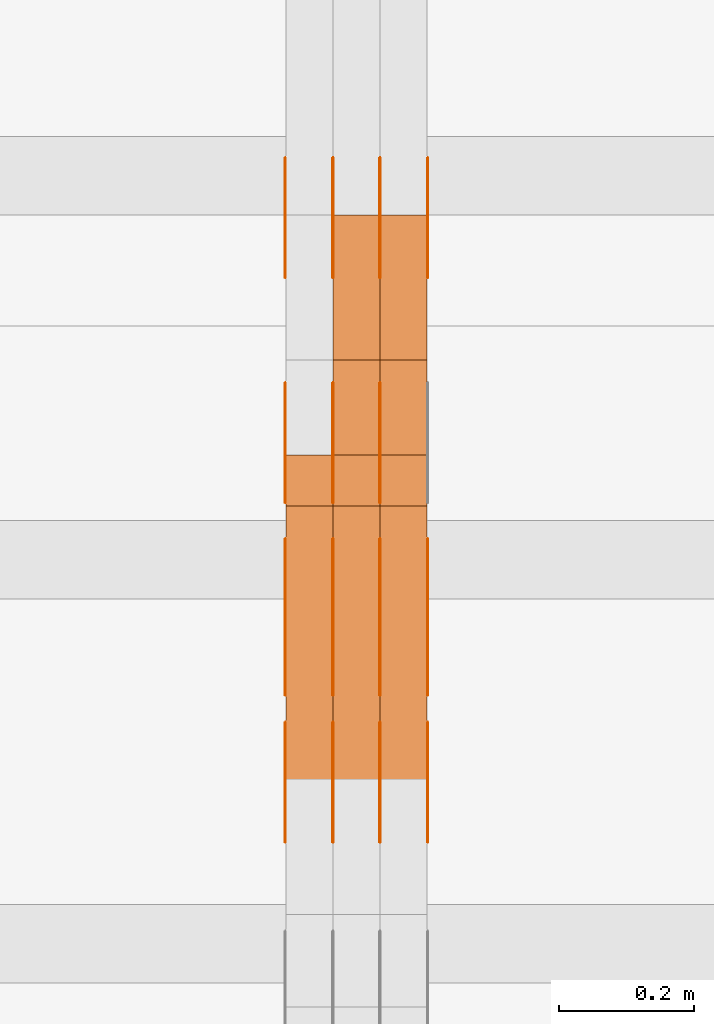
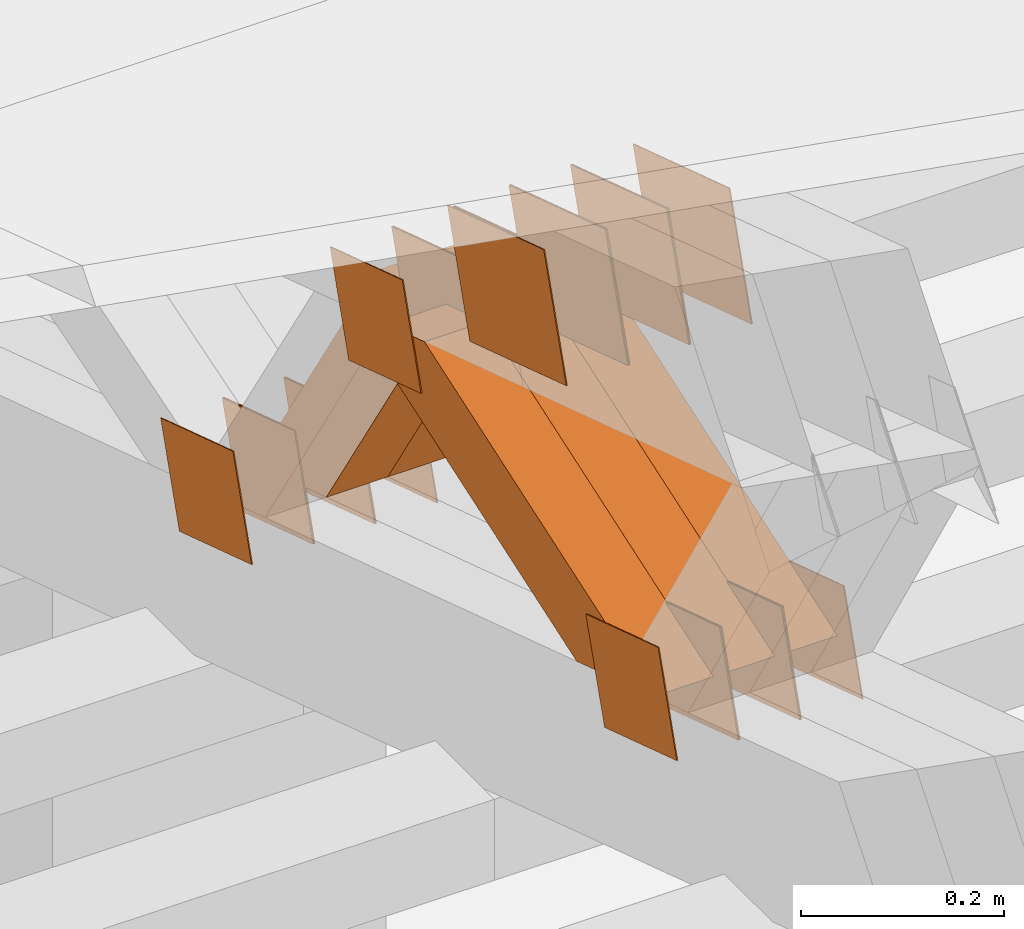
# One storey, part 332 of 385: 28 proxies.
"""IFC2X3 building model written with IfcOpenShell, lengths in millimetres."""

from ifc_helpers import new_model, entity, si_unit, converted_unit, derived_unit, direction, frame, origin, place, context, subcontext, project, spatial, polyline, outline, extrude, source, transform, mapped, material, type_object, type_shapes, element, save


model = new_model("IFC2X3")

# Units and contexts
model_context = context("Model", 3, precision=0.01, world=origin(), true_north=direction((6.12303176911189e-17, 1.0)))
body_context = subcontext(model_context, "Body", "Model", "MODEL_VIEW")
ifc_project = project(units=[si_unit("LENGTHUNIT", "METRE", prefix="MILLI"), si_unit("AREAUNIT", "SQUARE_METRE"), si_unit("VOLUMEUNIT", "CUBIC_METRE"), converted_unit("PLANEANGLEUNIT", "DEGREE", entity("IfcRatioMeasure", 0.0174532925199433), si_unit("PLANEANGLEUNIT", "RADIAN"), dimensions=[0, 0, 0, 0, 0, 0, 0]), si_unit("MASSUNIT", "GRAM", prefix="KILO"), derived_unit("MASSDENSITYUNIT", [(si_unit("MASSUNIT", "GRAM", prefix="KILO"), 1), (si_unit("LENGTHUNIT", "METRE"), -3)]), si_unit("TIMEUNIT", "SECOND"), si_unit("FREQUENCYUNIT", "HERTZ"), si_unit("THERMODYNAMICTEMPERATUREUNIT", "DEGREE_CELSIUS"), derived_unit("THERMALTRANSMITTANCEUNIT", [(si_unit("MASSUNIT", "GRAM", prefix="KILO"), 1), (si_unit("THERMODYNAMICTEMPERATUREUNIT", "KELVIN"), -1), (si_unit("TIMEUNIT", "SECOND"), -3)]), derived_unit("VOLUMETRICFLOWRATEUNIT", [(si_unit("LENGTHUNIT", "METRE"), 3), (si_unit("TIMEUNIT", "SECOND"), -1)]), si_unit("ELECTRICCURRENTUNIT", "AMPERE"), si_unit("ELECTRICVOLTAGEUNIT", "VOLT"), si_unit("POWERUNIT", "WATT"), si_unit("FORCEUNIT", "NEWTON", prefix="KILO"), si_unit("ILLUMINANCEUNIT", "LUX"), si_unit("LUMINOUSFLUXUNIT", "LUMEN"), si_unit("LUMINOUSINTENSITYUNIT", "CANDELA"), derived_unit("USERDEFINED", [(si_unit("MASSUNIT", "GRAM", prefix="KILO"), -1), (si_unit("LENGTHUNIT", "METRE"), -2), (si_unit("TIMEUNIT", "SECOND"), 3), (si_unit("LUMINOUSFLUXUNIT", "LUMEN"), 1)]), derived_unit("LINEARVELOCITYUNIT", [(si_unit("LENGTHUNIT", "METRE"), 1), (si_unit("TIMEUNIT", "SECOND"), -1)]), si_unit("PRESSUREUNIT", "PASCAL"), derived_unit("USERDEFINED", [(si_unit("LENGTHUNIT", "METRE"), -2), (si_unit("MASSUNIT", "GRAM", prefix="KILO"), 1), (si_unit("TIMEUNIT", "SECOND"), -2)])], contexts=[model_context])

# Site, building, storey
site_placement = place(None, origin())
site = spatial("IfcSite", under=ifc_project, at=site_placement, CompositionType="ELEMENT")
building_placement = place(site_placement, origin())
building = spatial("IfcBuilding", under=site, at=building_placement, CompositionType="ELEMENT")
storey_placement = place(building_placement, origin())
storey = spatial("IfcBuildingStorey", under=building, at=storey_placement, Name="Default", CompositionType="ELEMENT", Elevation=0.0)

# Proxies
ifc_material_1 = material(Name="IfcSurfaceStyle #418753")
building_element_proxy_type_1 = type_object("IfcBuildingElementProxyType", PredefinedType="NOTDEFINED", material=ifc_material_1)
shared_shape_1 = source(origin(), body_context, "Body", "SweptSolid", [
    extrude(outline(polyline([(-74.9998605591059, -59.9999264677526), (74.999875428623, -59.9999264677526), (74.9998605591068, 59.9999264677526), (-74.9998754286239, 59.9999264677526), (-74.9998605591059, -59.9999264677526)])), frame((75.0000889884782, 60.0000460315623, 0.0), z_axis=(0.0, 0.0, 1.0), x_axis=(-1.0, 0.0, 0.0)), (0.0, 0.0, 1.0), 1.3),
])
type_shapes(building_element_proxy_type_1, [shared_shape_1])
proxy_1_placement = place(building_placement, frame((33315.0, 20621.9679769682, 2241.76551219004), z_axis=(-1.0, 0.0, 0.0), x_axis=(0.0, -0.951056516295154, 0.309016994374948)))
element("IfcBuildingElementProxy", 1, at=proxy_1_placement, inside=storey, type_object=building_element_proxy_type_1, material=ifc_material_1, context=body_context, shape_type="MappedRepresentation", body=[
    mapped(shared_shape_1, transform((0.0, 0.0, 0.0), scale=1.0)),
])
ifc_material_2 = material(Name="IfcSurfaceStyle #418696")
building_element_proxy_type_2 = type_object("IfcBuildingElementProxyType", PredefinedType="NOTDEFINED", material=ifc_material_2)
shared_shape_2 = source(origin(), body_context, "Body", "SweptSolid", [
    extrude(outline(polyline([(-74.9998605591059, -59.9999264677526), (74.999875428623, -59.9999264677526), (74.9998605591068, 59.9999264677526), (-74.9998754286239, 59.9999264677526), (-74.9998605591059, -59.9999264677526)])), frame((75.0000889884782, 60.0000460315623, 0.0), z_axis=(0.0, 0.0, 1.0), x_axis=(-1.0, 0.0, 0.0)), (0.0, 0.0, 1.0), 1.3),
])
type_shapes(building_element_proxy_type_2, [shared_shape_2])
proxy_2_placement = place(building_placement, frame((33316.3, 20621.9679769682, 2241.76551219004), z_axis=(-1.0, 0.0, 0.0), x_axis=(0.0, -0.951056516295154, 0.309016994374948)))
element("IfcBuildingElementProxy", 2, at=proxy_2_placement, inside=storey, type_object=building_element_proxy_type_2, material=ifc_material_2, context=body_context, shape_type="MappedRepresentation", body=[
    mapped(shared_shape_2, transform((0.0, 0.0, 0.0), scale=1.0)),
])
ifc_material_3 = material(Name="IfcSurfaceStyle #418639")
building_element_proxy_type_3 = type_object("IfcBuildingElementProxyType", PredefinedType="NOTDEFINED", material=ifc_material_3)
shared_shape_3 = source(origin(), body_context, "Body", "SweptSolid", [
    extrude(outline(polyline([(-74.9998605591059, -59.9999264677526), (74.999875428623, -59.9999264677526), (74.9998605591068, 59.9999264677526), (-74.9998754286239, 59.9999264677526), (-74.9998605591059, -59.9999264677526)])), frame((75.0000889884782, 60.0000460315623, 0.0), z_axis=(0.0, 0.0, 1.0), x_axis=(-1.0, 0.0, 0.0)), (0.0, 0.0, 1.0), 1.29999999999999),
])
type_shapes(building_element_proxy_type_3, [shared_shape_3])
proxy_3_placement = place(building_placement, frame((33245.0, 20621.9679769682, 2241.76551219004), z_axis=(-1.0, 0.0, 0.0), x_axis=(0.0, -0.951056516295154, 0.309016994374948)))
element("IfcBuildingElementProxy", 3, at=proxy_3_placement, inside=storey, type_object=building_element_proxy_type_3, material=ifc_material_3, context=body_context, shape_type="MappedRepresentation", body=[
    mapped(shared_shape_3, transform((0.0, 0.0, 0.0), scale=1.0)),
])
ifc_material_4 = material(Name="IfcSurfaceStyle #418582")
building_element_proxy_type_4 = type_object("IfcBuildingElementProxyType", PredefinedType="NOTDEFINED", material=ifc_material_4)
shared_shape_4 = source(origin(), body_context, "Body", "SweptSolid", [
    extrude(outline(polyline([(-74.9998605591059, -59.9999264677526), (74.999875428623, -59.9999264677526), (74.9998605591068, 59.9999264677526), (-74.9998754286239, 59.9999264677526), (-74.9998605591059, -59.9999264677526)])), frame((75.0000889884782, 60.0000460315623, 0.0), z_axis=(0.0, 0.0, 1.0), x_axis=(-1.0, 0.0, 0.0)), (0.0, 0.0, 1.0), 1.29999999999999),
])
type_shapes(building_element_proxy_type_4, [shared_shape_4])
proxy_4_placement = place(building_placement, frame((33246.3, 20621.9679769682, 2241.76551219004), z_axis=(-1.0, 0.0, 0.0), x_axis=(0.0, -0.951056516295154, 0.309016994374948)))
element("IfcBuildingElementProxy", 4, at=proxy_4_placement, inside=storey, type_object=building_element_proxy_type_4, material=ifc_material_4, context=body_context, shape_type="MappedRepresentation", body=[
    mapped(shared_shape_4, transform((0.0, 0.0, 0.0), scale=1.0)),
])
ifc_material_5 = material(Name="IfcSurfaceStyle #418525")
building_element_proxy_type_5 = type_object("IfcBuildingElementProxyType", PredefinedType="NOTDEFINED", material=ifc_material_5)
shared_shape_5 = source(origin(), body_context, "Body", "SweptSolid", [
    extrude(outline(polyline([(-74.9998605591059, -59.9999264677526), (74.999875428623, -59.9999264677526), (74.9998605591068, 59.9999264677526), (-74.9998754286239, 59.9999264677526), (-74.9998605591059, -59.9999264677526)])), frame((75.0000889884782, 60.0000460315623, 0.0), z_axis=(0.0, 0.0, 1.0), x_axis=(-1.0, 0.0, 0.0)), (0.0, 0.0, 1.0), 1.29999999999999),
])
type_shapes(building_element_proxy_type_5, [shared_shape_5])
proxy_5_placement = place(building_placement, frame((33175.0, 20621.9679769682, 2241.76551219004), z_axis=(-1.0, 0.0, 0.0), x_axis=(0.0, -0.951056516295154, 0.309016994374948)))
element("IfcBuildingElementProxy", 5, at=proxy_5_placement, inside=storey, type_object=building_element_proxy_type_5, material=ifc_material_5, context=body_context, shape_type="MappedRepresentation", body=[
    mapped(shared_shape_5, transform((0.0, 0.0, 0.0), scale=1.0)),
])
ifc_material_6 = material(Name="IfcSurfaceStyle #417100")
building_element_proxy_type_6 = type_object("IfcBuildingElementProxyType", PredefinedType="NOTDEFINED", material=ifc_material_6)
shared_shape_6 = source(origin(), body_context, "Body", "SweptSolid", [
    extrude(outline(polyline([(-100.000260677523, -72.0000050220369), (100.000341220114, -72.0000050220369), (99.9997962944585, 72.0000050220369), (-99.9998768370492, 72.0000050220369), (-100.000260677523, -72.0000050220369)])), frame((100.000341220114, 72.0001826453454, 0.0), z_axis=(0.0, 0.0, 1.0), x_axis=(-1.0, 0.0, 0.0)), (0.0, 0.0, 1.0), 1.3),
])
type_shapes(building_element_proxy_type_6, [shared_shape_6])
proxy_6_placement = place(building_placement, frame((33386.3, 20382.8706354426, 2409.35285895246), z_axis=(-1.0, 0.0, 0.0), x_axis=(0.0, -0.951056516295154, 0.309016994374948)))
element("IfcBuildingElementProxy", 6, at=proxy_6_placement, inside=storey, type_object=building_element_proxy_type_6, material=ifc_material_6, context=body_context, shape_type="MappedRepresentation", body=[
    mapped(shared_shape_6, transform((0.0, 0.0, 0.0), scale=1.0)),
])
ifc_material_7 = material(Name="IfcSurfaceStyle #417043")
building_element_proxy_type_7 = type_object("IfcBuildingElementProxyType", PredefinedType="NOTDEFINED", material=ifc_material_7)
shared_shape_7 = source(origin(), body_context, "Body", "SweptSolid", [
    extrude(outline(polyline([(-100.000260677523, -72.0000050220369), (100.000341220114, -72.0000050220369), (99.9997962944585, 72.0000050220369), (-99.9998768370492, 72.0000050220369), (-100.000260677523, -72.0000050220369)])), frame((100.000341220114, 72.0001826453454, 0.0), z_axis=(0.0, 0.0, 1.0), x_axis=(-1.0, 0.0, 0.0)), (0.0, 0.0, 1.0), 1.3),
])
type_shapes(building_element_proxy_type_7, [shared_shape_7])
proxy_7_placement = place(building_placement, frame((33315.0, 20382.8706354426, 2409.35285895246), z_axis=(-1.0, 0.0, 0.0), x_axis=(0.0, -0.951056516295154, 0.309016994374948)))
element("IfcBuildingElementProxy", 7, at=proxy_7_placement, inside=storey, type_object=building_element_proxy_type_7, material=ifc_material_7, context=body_context, shape_type="MappedRepresentation", body=[
    mapped(shared_shape_7, transform((0.0, 0.0, 0.0), scale=1.0)),
])
ifc_material_8 = material(Name="IfcSurfaceStyle #416986")
building_element_proxy_type_8 = type_object("IfcBuildingElementProxyType", PredefinedType="NOTDEFINED", material=ifc_material_8)
shared_shape_8 = source(origin(), body_context, "Body", "SweptSolid", [
    extrude(outline(polyline([(-100.000260677523, -72.0000050220369), (100.000341220114, -72.0000050220369), (99.9997962944585, 72.0000050220369), (-99.9998768370492, 72.0000050220369), (-100.000260677523, -72.0000050220369)])), frame((100.000341220114, 72.0001826453454, 0.0), z_axis=(0.0, 0.0, 1.0), x_axis=(-1.0, 0.0, 0.0)), (0.0, 0.0, 1.0), 1.3),
])
type_shapes(building_element_proxy_type_8, [shared_shape_8])
proxy_8_placement = place(building_placement, frame((33316.3, 20382.8706354426, 2409.35285895246), z_axis=(-1.0, 0.0, 0.0), x_axis=(0.0, -0.951056516295154, 0.309016994374948)))
element("IfcBuildingElementProxy", 8, at=proxy_8_placement, inside=storey, type_object=building_element_proxy_type_8, material=ifc_material_8, context=body_context, shape_type="MappedRepresentation", body=[
    mapped(shared_shape_8, transform((0.0, 0.0, 0.0), scale=1.0)),
])
ifc_material_9 = material(Name="IfcSurfaceStyle #416929")
building_element_proxy_type_9 = type_object("IfcBuildingElementProxyType", PredefinedType="NOTDEFINED", material=ifc_material_9)
shared_shape_9 = source(origin(), body_context, "Body", "SweptSolid", [
    extrude(outline(polyline([(-100.000260677523, -72.0000050220369), (100.000341220114, -72.0000050220369), (99.9997962944585, 72.0000050220369), (-99.9998768370492, 72.0000050220369), (-100.000260677523, -72.0000050220369)])), frame((100.000341220114, 72.0001826453454, 0.0), z_axis=(0.0, 0.0, 1.0), x_axis=(-1.0, 0.0, 0.0)), (0.0, 0.0, 1.0), 1.29999999999998),
])
type_shapes(building_element_proxy_type_9, [shared_shape_9])
proxy_9_placement = place(building_placement, frame((33245.0, 20382.8706354426, 2409.35285895246), z_axis=(-1.0, 0.0, 0.0), x_axis=(0.0, -0.951056516295154, 0.309016994374948)))
element("IfcBuildingElementProxy", 9, at=proxy_9_placement, inside=storey, type_object=building_element_proxy_type_9, material=ifc_material_9, context=body_context, shape_type="MappedRepresentation", body=[
    mapped(shared_shape_9, transform((0.0, 0.0, 0.0), scale=1.0)),
])
ifc_material_10 = material(Name="IfcSurfaceStyle #416872")
building_element_proxy_type_10 = type_object("IfcBuildingElementProxyType", PredefinedType="NOTDEFINED", material=ifc_material_10)
shared_shape_10 = source(origin(), body_context, "Body", "SweptSolid", [
    extrude(outline(polyline([(-100.000260677523, -72.0000050220369), (100.000341220114, -72.0000050220369), (99.9997962944585, 72.0000050220369), (-99.9998768370492, 72.0000050220369), (-100.000260677523, -72.0000050220369)])), frame((100.000341220114, 72.0001826453454, 0.0), z_axis=(0.0, 0.0, 1.0), x_axis=(-1.0, 0.0, 0.0)), (0.0, 0.0, 1.0), 1.29999999999998),
])
type_shapes(building_element_proxy_type_10, [shared_shape_10])
proxy_10_placement = place(building_placement, frame((33246.3, 20382.8706354426, 2409.35285895246), z_axis=(-1.0, 0.0, 0.0), x_axis=(0.0, -0.951056516295154, 0.309016994374948)))
element("IfcBuildingElementProxy", 10, at=proxy_10_placement, inside=storey, type_object=building_element_proxy_type_10, material=ifc_material_10, context=body_context, shape_type="MappedRepresentation", body=[
    mapped(shared_shape_10, transform((0.0, 0.0, 0.0), scale=1.0)),
])
ifc_material_11 = material(Name="IfcSurfaceStyle #416815")
building_element_proxy_type_11 = type_object("IfcBuildingElementProxyType", PredefinedType="NOTDEFINED", material=ifc_material_11)
shared_shape_11 = source(origin(), body_context, "Body", "SweptSolid", [
    extrude(outline(polyline([(-100.000260677523, -72.0000050220369), (100.000341220114, -72.0000050220369), (99.9997962944585, 72.0000050220369), (-99.9998768370492, 72.0000050220369), (-100.000260677523, -72.0000050220369)])), frame((100.000341220114, 72.0001826453454, 0.0), z_axis=(0.0, 0.0, 1.0), x_axis=(-1.0, 0.0, 0.0)), (0.0, 0.0, 1.0), 1.29999999999999),
])
type_shapes(building_element_proxy_type_11, [shared_shape_11])
proxy_11_placement = place(building_placement, frame((33175.0, 20382.8706354426, 2409.35285895246), z_axis=(-1.0, 0.0, 0.0), x_axis=(0.0, -0.951056516295154, 0.309016994374948)))
element("IfcBuildingElementProxy", 11, at=proxy_11_placement, inside=storey, type_object=building_element_proxy_type_11, material=ifc_material_11, context=body_context, shape_type="MappedRepresentation", body=[
    mapped(shared_shape_11, transform((0.0, 0.0, 0.0), scale=1.0)),
])
ifc_material_12 = material(Name="IfcSurfaceStyle #410602")
building_element_proxy_type_12 = type_object("IfcBuildingElementProxyType", PredefinedType="NOTDEFINED", material=ifc_material_12)
shared_shape_12 = source(origin(), body_context, "Body", "SweptSolid", [
    extrude(outline(polyline([(-74.9998605591118, -59.9999264677598), (74.9998754286171, -59.9999264677598), (74.9998605591136, 59.9999264677598), (-74.9998754286189, 59.9999264677598), (-74.9998605591118, -59.9999264677598)])), frame((75.0000347664736, 60.0000016373434, 0.0), z_axis=(0.0, 0.0, 1.0), x_axis=(-1.0, 0.0, 0.0)), (0.0, 0.0, 1.0), 1.3),
])
type_shapes(building_element_proxy_type_12, [shared_shape_12])
proxy_12_placement = place(building_placement, frame((33386.3, 20117.0890328685, 2105.40814929196), z_axis=(-1.0, 0.0, 0.0), x_axis=(0.0, -0.951056516295124, 0.309016994375039)))
element("IfcBuildingElementProxy", 12, at=proxy_12_placement, inside=storey, type_object=building_element_proxy_type_12, material=ifc_material_12, context=body_context, shape_type="MappedRepresentation", body=[
    mapped(shared_shape_12, transform((0.0, 0.0, 0.0), scale=1.0)),
])
ifc_material_13 = material(Name="IfcSurfaceStyle #410545")
building_element_proxy_type_13 = type_object("IfcBuildingElementProxyType", PredefinedType="NOTDEFINED", material=ifc_material_13)
shared_shape_13 = source(origin(), body_context, "Body", "SweptSolid", [
    extrude(outline(polyline([(-74.9998605591118, -59.9999264677598), (74.9998754286171, -59.9999264677598), (74.9998605591136, 59.9999264677598), (-74.9998754286189, 59.9999264677598), (-74.9998605591118, -59.9999264677598)])), frame((75.0000347664736, 60.0000016373434, 0.0), z_axis=(0.0, 0.0, 1.0), x_axis=(-1.0, 0.0, 0.0)), (0.0, 0.0, 1.0), 1.3),
])
type_shapes(building_element_proxy_type_13, [shared_shape_13])
proxy_13_placement = place(building_placement, frame((33315.0, 20117.0890328685, 2105.40814929196), z_axis=(-1.0, 0.0, 0.0), x_axis=(0.0, -0.951056516295124, 0.309016994375039)))
element("IfcBuildingElementProxy", 13, at=proxy_13_placement, inside=storey, type_object=building_element_proxy_type_13, material=ifc_material_13, context=body_context, shape_type="MappedRepresentation", body=[
    mapped(shared_shape_13, transform((0.0, 0.0, 0.0), scale=1.0)),
])
ifc_material_14 = material(Name="IfcSurfaceStyle #410488")
building_element_proxy_type_14 = type_object("IfcBuildingElementProxyType", PredefinedType="NOTDEFINED", material=ifc_material_14)
shared_shape_14 = source(origin(), body_context, "Body", "SweptSolid", [
    extrude(outline(polyline([(-74.9998605591118, -59.9999264677598), (74.9998754286171, -59.9999264677598), (74.9998605591136, 59.9999264677598), (-74.9998754286189, 59.9999264677598), (-74.9998605591118, -59.9999264677598)])), frame((75.0000347664736, 60.0000016373434, 0.0), z_axis=(0.0, 0.0, 1.0), x_axis=(-1.0, 0.0, 0.0)), (0.0, 0.0, 1.0), 1.3),
])
type_shapes(building_element_proxy_type_14, [shared_shape_14])
proxy_14_placement = place(building_placement, frame((33316.3, 20117.0890328685, 2105.40814929196), z_axis=(-1.0, 0.0, 0.0), x_axis=(0.0, -0.951056516295124, 0.309016994375039)))
element("IfcBuildingElementProxy", 14, at=proxy_14_placement, inside=storey, type_object=building_element_proxy_type_14, material=ifc_material_14, context=body_context, shape_type="MappedRepresentation", body=[
    mapped(shared_shape_14, transform((0.0, 0.0, 0.0), scale=1.0)),
])
ifc_material_15 = material(Name="IfcSurfaceStyle #410431")
building_element_proxy_type_15 = type_object("IfcBuildingElementProxyType", PredefinedType="NOTDEFINED", material=ifc_material_15)
shared_shape_15 = source(origin(), body_context, "Body", "SweptSolid", [
    extrude(outline(polyline([(-74.9998605591118, -59.9999264677598), (74.9998754286171, -59.9999264677598), (74.9998605591136, 59.9999264677598), (-74.9998754286189, 59.9999264677598), (-74.9998605591118, -59.9999264677598)])), frame((75.0000347664736, 60.0000016373434, 0.0), z_axis=(0.0, 0.0, 1.0), x_axis=(-1.0, 0.0, 0.0)), (0.0, 0.0, 1.0), 1.29999999999999),
])
type_shapes(building_element_proxy_type_15, [shared_shape_15])
proxy_15_placement = place(building_placement, frame((33245.0, 20117.0890328685, 2105.40814929196), z_axis=(-1.0, 0.0, 0.0), x_axis=(0.0, -0.951056516295124, 0.309016994375039)))
element("IfcBuildingElementProxy", 15, at=proxy_15_placement, inside=storey, type_object=building_element_proxy_type_15, material=ifc_material_15, context=body_context, shape_type="MappedRepresentation", body=[
    mapped(shared_shape_15, transform((0.0, 0.0, 0.0), scale=1.0)),
])
ifc_material_16 = material(Name="IfcSurfaceStyle #410374")
building_element_proxy_type_16 = type_object("IfcBuildingElementProxyType", PredefinedType="NOTDEFINED", material=ifc_material_16)
shared_shape_16 = source(origin(), body_context, "Body", "SweptSolid", [
    extrude(outline(polyline([(-74.9998605591118, -59.9999264677598), (74.9998754286171, -59.9999264677598), (74.9998605591136, 59.9999264677598), (-74.9998754286189, 59.9999264677598), (-74.9998605591118, -59.9999264677598)])), frame((75.0000347664736, 60.0000016373434, 0.0), z_axis=(0.0, 0.0, 1.0), x_axis=(-1.0, 0.0, 0.0)), (0.0, 0.0, 1.0), 1.29999999999999),
])
type_shapes(building_element_proxy_type_16, [shared_shape_16])
proxy_16_placement = place(building_placement, frame((33246.3, 20117.0890328685, 2105.40814929196), z_axis=(-1.0, 0.0, 0.0), x_axis=(0.0, -0.951056516295124, 0.309016994375039)))
element("IfcBuildingElementProxy", 16, at=proxy_16_placement, inside=storey, type_object=building_element_proxy_type_16, material=ifc_material_16, context=body_context, shape_type="MappedRepresentation", body=[
    mapped(shared_shape_16, transform((0.0, 0.0, 0.0), scale=1.0)),
])
ifc_material_17 = material(Name="IfcSurfaceStyle #410317")
building_element_proxy_type_17 = type_object("IfcBuildingElementProxyType", PredefinedType="NOTDEFINED", material=ifc_material_17)
shared_shape_17 = source(origin(), body_context, "Body", "SweptSolid", [
    extrude(outline(polyline([(-74.9998605591118, -59.9999264677598), (74.9998754286171, -59.9999264677598), (74.9998605591136, 59.9999264677598), (-74.9998754286189, 59.9999264677598), (-74.9998605591118, -59.9999264677598)])), frame((75.0000347664736, 60.0000016373434, 0.0), z_axis=(0.0, 0.0, 1.0), x_axis=(-1.0, 0.0, 0.0)), (0.0, 0.0, 1.0), 1.29999999999999),
])
type_shapes(building_element_proxy_type_17, [shared_shape_17])
proxy_17_placement = place(building_placement, frame((33175.0, 20117.0890328685, 2105.40814929196), z_axis=(-1.0, 0.0, 0.0), x_axis=(0.0, -0.951056516295124, 0.309016994375039)))
element("IfcBuildingElementProxy", 17, at=proxy_17_placement, inside=storey, type_object=building_element_proxy_type_17, material=ifc_material_17, context=body_context, shape_type="MappedRepresentation", body=[
    mapped(shared_shape_17, transform((0.0, 0.0, 0.0), scale=1.0)),
])
ifc_material_18 = material(Name="IfcSurfaceStyle #410260")
building_element_proxy_type_18 = type_object("IfcBuildingElementProxyType", PredefinedType="NOTDEFINED", material=ifc_material_18)
shared_shape_18 = source(origin(), body_context, "Body", "SweptSolid", [
    extrude(outline(polyline([(-74.9998794200132, -59.999984515643), (74.9998565677174, -59.999984515643), (74.9998794200123, 59.999984515643), (-74.9998565677165, 59.999984515643), (-74.9998794200132, -59.999984515643)])), frame((75.0002235343086, 60.0000596852268, 0.0), z_axis=(0.0, 0.0, 1.0), x_axis=(-1.0, 0.0, 0.0)), (0.0, 0.0, 1.0), 1.3),
])
type_shapes(building_element_proxy_type_18, [shared_shape_18])
proxy_18_placement = place(building_placement, frame((33386.3, 20956.2317725846, 1832.75404405346), z_axis=(-1.0, 0.0, 0.0), x_axis=(0.0, -0.951056516295124, 0.309016994375039)))
element("IfcBuildingElementProxy", 18, at=proxy_18_placement, inside=storey, type_object=building_element_proxy_type_18, material=ifc_material_18, context=body_context, shape_type="MappedRepresentation", body=[
    mapped(shared_shape_18, transform((0.0, 0.0, 0.0), scale=1.0)),
])
ifc_material_19 = material(Name="IfcSurfaceStyle #410203")
building_element_proxy_type_19 = type_object("IfcBuildingElementProxyType", PredefinedType="NOTDEFINED", material=ifc_material_19)
shared_shape_19 = source(origin(), body_context, "Body", "SweptSolid", [
    extrude(outline(polyline([(-74.9998794200132, -59.999984515643), (74.9998565677174, -59.999984515643), (74.9998794200123, 59.999984515643), (-74.9998565677165, 59.999984515643), (-74.9998794200132, -59.999984515643)])), frame((75.0002235343086, 60.0000596852268, 0.0), z_axis=(0.0, 0.0, 1.0), x_axis=(-1.0, 0.0, 0.0)), (0.0, 0.0, 1.0), 1.3),
])
type_shapes(building_element_proxy_type_19, [shared_shape_19])
proxy_19_placement = place(building_placement, frame((33315.0, 20956.2317725846, 1832.75404405346), z_axis=(-1.0, 0.0, 0.0), x_axis=(0.0, -0.951056516295124, 0.309016994375039)))
element("IfcBuildingElementProxy", 19, at=proxy_19_placement, inside=storey, type_object=building_element_proxy_type_19, material=ifc_material_19, context=body_context, shape_type="MappedRepresentation", body=[
    mapped(shared_shape_19, transform((0.0, 0.0, 0.0), scale=1.0)),
])
ifc_material_20 = material(Name="IfcSurfaceStyle #410146")
building_element_proxy_type_20 = type_object("IfcBuildingElementProxyType", PredefinedType="NOTDEFINED", material=ifc_material_20)
shared_shape_20 = source(origin(), body_context, "Body", "SweptSolid", [
    extrude(outline(polyline([(-74.9998794200132, -59.999984515643), (74.9998565677174, -59.999984515643), (74.9998794200123, 59.999984515643), (-74.9998565677165, 59.999984515643), (-74.9998794200132, -59.999984515643)])), frame((75.0002235343086, 60.0000596852268, 0.0), z_axis=(0.0, 0.0, 1.0), x_axis=(-1.0, 0.0, 0.0)), (0.0, 0.0, 1.0), 1.3),
])
type_shapes(building_element_proxy_type_20, [shared_shape_20])
proxy_20_placement = place(building_placement, frame((33316.3, 20956.2317725846, 1832.75404405346), z_axis=(-1.0, 0.0, 0.0), x_axis=(0.0, -0.951056516295124, 0.309016994375039)))
element("IfcBuildingElementProxy", 20, at=proxy_20_placement, inside=storey, type_object=building_element_proxy_type_20, material=ifc_material_20, context=body_context, shape_type="MappedRepresentation", body=[
    mapped(shared_shape_20, transform((0.0, 0.0, 0.0), scale=1.0)),
])
ifc_material_21 = material(Name="IfcSurfaceStyle #410089")
building_element_proxy_type_21 = type_object("IfcBuildingElementProxyType", PredefinedType="NOTDEFINED", material=ifc_material_21)
shared_shape_21 = source(origin(), body_context, "Body", "SweptSolid", [
    extrude(outline(polyline([(-74.9998794200132, -59.999984515643), (74.9998565677174, -59.999984515643), (74.9998794200123, 59.999984515643), (-74.9998565677165, 59.999984515643), (-74.9998794200132, -59.999984515643)])), frame((75.0002235343086, 60.0000596852268, 0.0), z_axis=(0.0, 0.0, 1.0), x_axis=(-1.0, 0.0, 0.0)), (0.0, 0.0, 1.0), 1.29999999999999),
])
type_shapes(building_element_proxy_type_21, [shared_shape_21])
proxy_21_placement = place(building_placement, frame((33245.0, 20956.2317725846, 1832.75404405346), z_axis=(-1.0, 0.0, 0.0), x_axis=(0.0, -0.951056516295124, 0.309016994375039)))
element("IfcBuildingElementProxy", 21, at=proxy_21_placement, inside=storey, type_object=building_element_proxy_type_21, material=ifc_material_21, context=body_context, shape_type="MappedRepresentation", body=[
    mapped(shared_shape_21, transform((0.0, 0.0, 0.0), scale=1.0)),
])
ifc_material_22 = material(Name="IfcSurfaceStyle #410032")
building_element_proxy_type_22 = type_object("IfcBuildingElementProxyType", PredefinedType="NOTDEFINED", material=ifc_material_22)
shared_shape_22 = source(origin(), body_context, "Body", "SweptSolid", [
    extrude(outline(polyline([(-74.9998794200132, -59.999984515643), (74.9998565677174, -59.999984515643), (74.9998794200123, 59.999984515643), (-74.9998565677165, 59.999984515643), (-74.9998794200132, -59.999984515643)])), frame((75.0002235343086, 60.0000596852268, 0.0), z_axis=(0.0, 0.0, 1.0), x_axis=(-1.0, 0.0, 0.0)), (0.0, 0.0, 1.0), 1.29999999999999),
])
type_shapes(building_element_proxy_type_22, [shared_shape_22])
proxy_22_placement = place(building_placement, frame((33246.3, 20956.2317725846, 1832.75404405346), z_axis=(-1.0, 0.0, 0.0), x_axis=(0.0, -0.951056516295124, 0.309016994375039)))
element("IfcBuildingElementProxy", 22, at=proxy_22_placement, inside=storey, type_object=building_element_proxy_type_22, material=ifc_material_22, context=body_context, shape_type="MappedRepresentation", body=[
    mapped(shared_shape_22, transform((0.0, 0.0, 0.0), scale=1.0)),
])
ifc_material_23 = material(Name="IfcSurfaceStyle #409975")
building_element_proxy_type_23 = type_object("IfcBuildingElementProxyType", PredefinedType="NOTDEFINED", material=ifc_material_23)
shared_shape_23 = source(origin(), body_context, "Body", "SweptSolid", [
    extrude(outline(polyline([(-74.9998794200132, -59.999984515643), (74.9998565677174, -59.999984515643), (74.9998794200123, 59.999984515643), (-74.9998565677165, 59.999984515643), (-74.9998794200132, -59.999984515643)])), frame((75.0002235343086, 60.0000596852268, 0.0), z_axis=(0.0, 0.0, 1.0), x_axis=(-1.0, 0.0, 0.0)), (0.0, 0.0, 1.0), 1.29999999999999),
])
type_shapes(building_element_proxy_type_23, [shared_shape_23])
proxy_23_placement = place(building_placement, frame((33175.0, 20956.2317725846, 1832.75404405346), z_axis=(-1.0, 0.0, 0.0), x_axis=(0.0, -0.951056516295124, 0.309016994375039)))
element("IfcBuildingElementProxy", 23, at=proxy_23_placement, inside=storey, type_object=building_element_proxy_type_23, material=ifc_material_23, context=body_context, shape_type="MappedRepresentation", body=[
    mapped(shared_shape_23, transform((0.0, 0.0, 0.0), scale=1.0)),
])
ifc_material_24 = material(Name="IfcSurfaceStyle #392998")
building_element_proxy_type_24 = type_object("IfcBuildingElementProxyType", Name="T1-W26 392996", PredefinedType="NOTDEFINED", material=ifc_material_24)
shared_shape_24 = source(origin(), body_context, "Body", "SweptSolid", [
    extrude(outline(polyline([(-339.390941716546, -47.5001331548025), (137.738864791781, -47.5001331548025), (201.272298560955, 6.02772073885038e-05), (212.703852542003, 47.5001030161988), (-212.324074178193, 47.5001030161988), (-339.390941716546, -47.5001331548025)])), frame((212.703852542003, 47.5001030161988, 0.0), z_axis=(0.0, 0.0, 1.0), x_axis=(-1.0, 0.0, 0.0)), (0.0, 0.0, 1.0), 70.0),
])
type_shapes(building_element_proxy_type_24, [shared_shape_24])
proxy_24_placement = place(building_placement, frame((33385.0, 20576.541015625, 2286.80981445313), z_axis=(-1.0, 0.0, 0.0), x_axis=(0.0, -0.946743816465327, -0.321987804093053)))
element("IfcBuildingElementProxy", 24, at=proxy_24_placement, inside=storey, type_object=building_element_proxy_type_24, material=ifc_material_24, Name="T1-W26", context=body_context, shape_type="MappedRepresentation", body=[
    mapped(shared_shape_24, transform((0.0, 0.0, 0.0), scale=1.0)),
])
ifc_material_25 = material(Name="IfcSurfaceStyle #392932")
building_element_proxy_type_25 = type_object("IfcBuildingElementProxyType", Name="T1-W26 392930", PredefinedType="NOTDEFINED", material=ifc_material_25)
shared_shape_25 = source(origin(), body_context, "Body", "SweptSolid", [
    extrude(outline(polyline([(-339.390941716546, -47.5001331548025), (137.738864791781, -47.5001331548025), (201.272298560955, 6.02772073885038e-05), (212.703852542003, 47.5001030161988), (-212.324074178193, 47.5001030161988), (-339.390941716546, -47.5001331548025)])), frame((212.703852542003, 47.5001030161988, 0.0), z_axis=(0.0, 0.0, 1.0), x_axis=(-1.0, 0.0, 0.0)), (0.0, 0.0, 1.0), 70.0),
])
type_shapes(building_element_proxy_type_25, [shared_shape_25])
proxy_25_placement = place(building_placement, frame((33315.0, 20576.541015625, 2286.80981445313), z_axis=(-1.0, 0.0, 0.0), x_axis=(0.0, -0.946743816465327, -0.321987804093053)))
element("IfcBuildingElementProxy", 25, at=proxy_25_placement, inside=storey, type_object=building_element_proxy_type_25, material=ifc_material_25, Name="T1-W26", context=body_context, shape_type="MappedRepresentation", body=[
    mapped(shared_shape_25, transform((0.0, 0.0, 0.0), scale=1.0)),
])
ifc_material_26 = material(Name="IfcSurfaceStyle #392866")
building_element_proxy_type_26 = type_object("IfcBuildingElementProxyType", Name="T1-W26 392864", PredefinedType="NOTDEFINED", material=ifc_material_26)
shared_shape_26 = source(origin(), body_context, "Body", "SweptSolid", [
    extrude(outline(polyline([(-339.390941716546, -47.5001331548025), (137.738864791781, -47.5001331548025), (201.272298560955, 6.02772073885038e-05), (212.703852542003, 47.5001030161988), (-212.324074178193, 47.5001030161988), (-339.390941716546, -47.5001331548025)])), frame((212.703852542003, 47.5001030161988, 0.0), z_axis=(0.0, 0.0, 1.0), x_axis=(-1.0, 0.0, 0.0)), (0.0, 0.0, 1.0), 70.0),
])
type_shapes(building_element_proxy_type_26, [shared_shape_26])
proxy_26_placement = place(building_placement, frame((33245.0, 20576.541015625, 2286.80981445313), z_axis=(-1.0, 0.0, 0.0), x_axis=(0.0, -0.946743816465327, -0.321987804093053)))
element("IfcBuildingElementProxy", 26, at=proxy_26_placement, inside=storey, type_object=building_element_proxy_type_26, material=ifc_material_26, Name="T1-W26", context=body_context, shape_type="MappedRepresentation", body=[
    mapped(shared_shape_26, transform((0.0, 0.0, 0.0), scale=1.0)),
])
ifc_material_27 = material(Name="IfcSurfaceStyle #392602")
building_element_proxy_type_27 = type_object("IfcBuildingElementProxyType", Name="T1-W29 392600", PredefinedType="NOTDEFINED", material=ifc_material_27)
shared_shape_27 = source(origin(), body_context, "Body", "SweptSolid", [
    extrude(outline(polyline([(-202.325994317059, -47.5000867467013), (200.714255560873, -47.5000867467013), (187.834128885383, 0.000593513395139059), (130.590899902046, 47.4997899900038), (-316.813290031243, 47.4997899900038), (-202.325994317059, -47.5000867467013)])), frame((200.714255560873, 47.5001935424745, 0.0), z_axis=(0.0, 0.0, 1.0), x_axis=(-1.0, 0.0, 0.0)), (0.0, 0.0, 1.0), 70.0),
])
type_shapes(building_element_proxy_type_27, [shared_shape_27])
proxy_27_placement = place(building_placement, frame((33385.0, 20827.0771193222, 1890.72342063252), z_axis=(-1.0, 0.0, 0.0), x_axis=(0.0, -0.534567451138397, 0.845125813227473)))
element("IfcBuildingElementProxy", 27, at=proxy_27_placement, inside=storey, type_object=building_element_proxy_type_27, material=ifc_material_27, Name="T1-W29", context=body_context, shape_type="MappedRepresentation", body=[
    mapped(shared_shape_27, transform((0.0, 0.0, 0.0), scale=1.0)),
])
ifc_material_28 = material(Name="IfcSurfaceStyle #392536")
building_element_proxy_type_28 = type_object("IfcBuildingElementProxyType", Name="T1-W29 392534", PredefinedType="NOTDEFINED", material=ifc_material_28)
shared_shape_28 = source(origin(), body_context, "Body", "SweptSolid", [
    extrude(outline(polyline([(-202.325994317059, -47.5000867467013), (200.714255560873, -47.5000867467013), (187.834128885383, 0.000593513395139059), (130.590899902046, 47.4997899900038), (-316.813290031243, 47.4997899900038), (-202.325994317059, -47.5000867467013)])), frame((200.714255560873, 47.5001935424745, 0.0), z_axis=(0.0, 0.0, 1.0), x_axis=(-1.0, 0.0, 0.0)), (0.0, 0.0, 1.0), 70.0),
])
type_shapes(building_element_proxy_type_28, [shared_shape_28])
proxy_28_placement = place(building_placement, frame((33315.0, 20827.0771193222, 1890.72342063252), z_axis=(-1.0, 0.0, 0.0), x_axis=(0.0, -0.534567451138397, 0.845125813227473)))
element("IfcBuildingElementProxy", 28, at=proxy_28_placement, inside=storey, type_object=building_element_proxy_type_28, material=ifc_material_28, Name="T1-W29", context=body_context, shape_type="MappedRepresentation", body=[
    mapped(shared_shape_28, transform((0.0, 0.0, 0.0), scale=1.0)),
])

save(model, "model.ifc")
